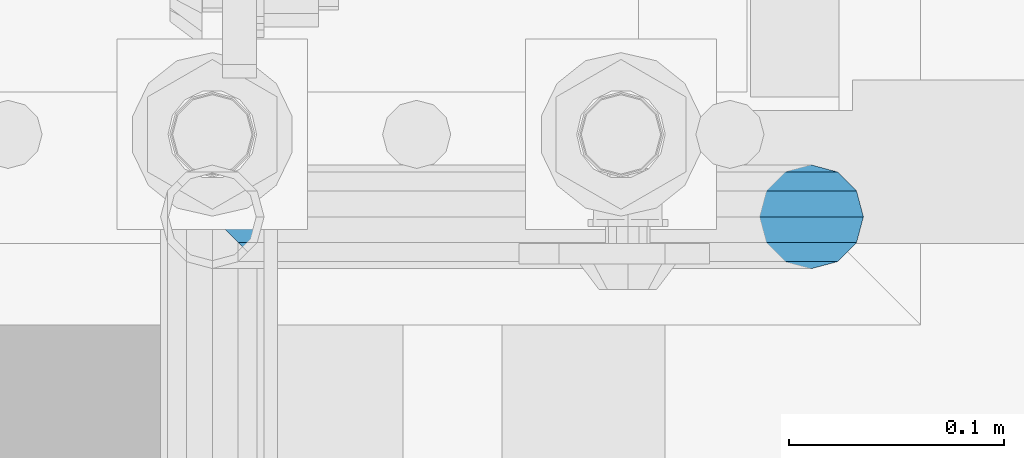
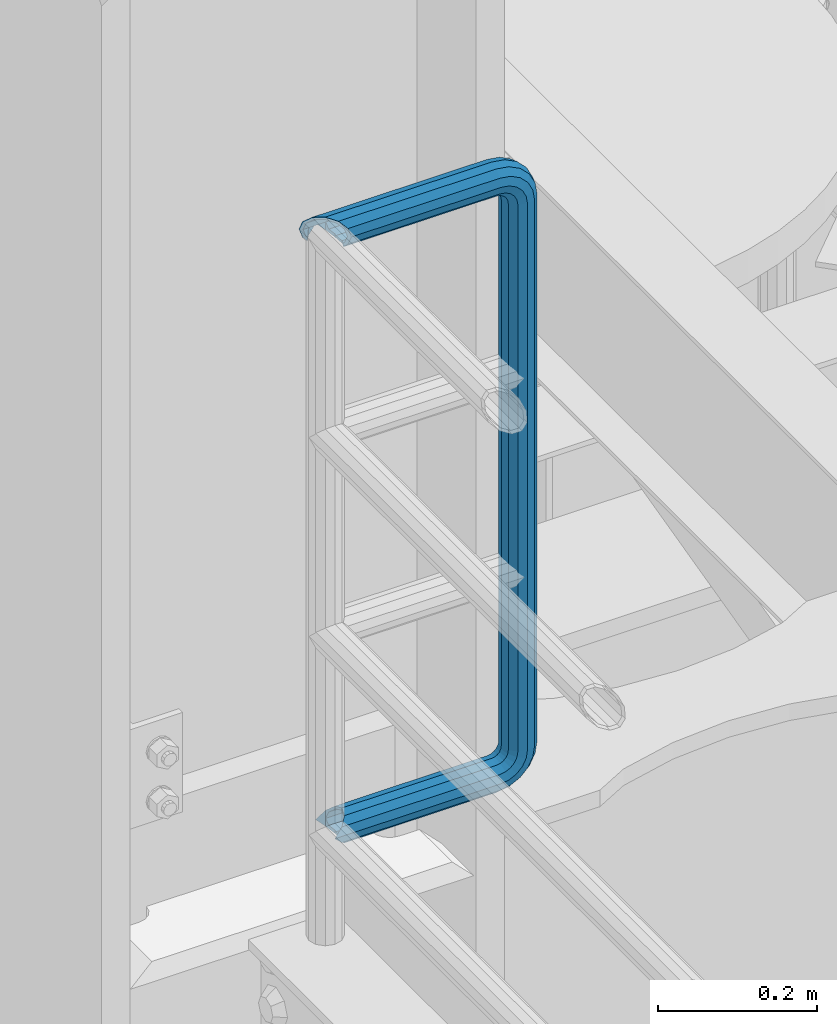
# One storey, part 960 of 1876: 1 beam, 1 element without a shape of its own.
"""IFC2X3 building model written with IfcOpenShell, lengths in millimetres."""

from ifc_helpers import new_model, si_unit, frame, origin_with_axes, place, context, subcontext, project, spatial, faceted_brep, material, type_object, element, aggregate, save


model = new_model("IFC2X3")

# Units and contexts
model_context = context("Model", 3, precision=1e-05, world=origin_with_axes())
body_context = subcontext(model_context, "Body", "Model", "MODEL_VIEW")
ifc_project = project(units=[si_unit("LENGTHUNIT", "METRE", prefix="MILLI"), si_unit("AREAUNIT", "SQUARE_METRE"), si_unit("VOLUMEUNIT", "CUBIC_METRE"), si_unit("MASSUNIT", "GRAM", prefix="KILO"), si_unit("TIMEUNIT", "SECOND"), si_unit("PLANEANGLEUNIT", "RADIAN"), si_unit("SOLIDANGLEUNIT", "STERADIAN"), si_unit("THERMODYNAMICTEMPERATUREUNIT", "DEGREE_CELSIUS"), si_unit("LUMINOUSINTENSITYUNIT", "LUMEN")], contexts=[model_context])

# Site, building, storey
site_placement = place(None, origin_with_axes())
site = spatial("IfcSite", under=ifc_project, at=site_placement, CompositionType="ELEMENT")
building_placement = place(site_placement, origin_with_axes())
building = spatial("IfcBuilding", under=site, at=building_placement, Name="Undefined", CompositionType="ELEMENT")
storey_placement = place(building_placement, origin_with_axes())
storey = spatial("IfcBuildingStorey", under=building, at=storey_placement, Name="Undefined", CompositionType="ELEMENT", Elevation=0.0)

# Assembly, beam
assembly_placement = place(storey_placement, origin_with_axes())
assembly = element("IfcElementAssembly", 1, at=assembly_placement, inside=storey, Name="RAIL", AssemblyPlace="NOTDEFINED", PredefinedType="RIGID_FRAME")
ifc_material = material()
beam_type = type_object("IfcBeamType", Name="PIPE1-1/2SCH40", PredefinedType="NOTDEFINED")
beam_placement = place(assembly_placement, frame((5.00222085975111e-12, -4788.2175, 19059.525), z_axis=(0.0, 0.0, 1.0), x_axis=(1.0, 0.0, 0.0)))
beam = element("IfcBeam", 2, at=beam_placement, type_object=beam_type, material=ifc_material, Name="RAIL", ObjectType="PIPE1-1/2SCH40", context=body_context, shape_type="Brep", body=[
    faceted_brep([(-12.0649999999986, 20.8971929933177, -12.0649999999987), (-12.0649999999986, 20.8971929933186, 0.0), (-12.5151929933171, 20.4470000000001, 0.0), (-15.2545715621367, 17.7076214311801, -10.2235000000001), (-16.4810964966549, 16.4810964966618, -11.4500249345183), (-16.481093238746, 16.4810932387318, -16.4810997545865), (0.0, 24.1299999999992, 0.0), (12.0650000000014, 20.8971929933186, 0.0), (12.5151929933249, 20.4470000000001, 0.0), (12.0650000000064, 20.8971929933177, -12.0649999999987), (15.2545715621445, 17.7076214311801, -10.2235000000001), (20.8971929933249, 12.0650000000005, -20.8971929933177), (20.8971929933249, 12.0650000000005, -15.8661214311796), (20.8971929933249, -12.0650000000005, -15.8661214311796), (20.8971929933249, -12.0650000000005, -20.8971929933177), (16.4810997545745, -16.4810997545883, -16.48109323873), (16.4810964966636, -16.4810964966564, -11.4500249345256), (24.1300000000063, 0.0, -20.4470000000001), (24.1300000000063, 0.0, -24.130000000001), (21.3906214311868, -10.2235000000001, -17.7076214311819), (21.3906214311868, 10.2235000000001, -17.7076214311819), (1.20714750983051e-12, 24.1299999999974, -914.399963378906), (12.0650000000014, 20.8971929933159, -926.464963378905), (12.0650000000014, 20.8971929933177, -902.334963378908), (12.0650000000014, -20.8971929933195, -902.334963378908), (12.0650000000014, -20.8971929933195, -926.464963378905), (1.52133659548828e-12, -24.130000000001, -914.399963378906), (20.8971929933199, -12.0650000000023, -893.502770385589), (20.8971929933199, -12.0650000000005, -898.533841947723), (15.2545715621378, -17.7076214311819, -904.176463378906), (12.5151929933181, -20.4470000000019, -914.399963378906), (15.2545715621376, -17.7076214311819, -924.623463378906), (20.8971929933199, -12.0650000000005, -930.26608481009), (20.8971929933199, -12.0650000000023, -935.297156372224), (24.1300000000014, -1.81898940354586e-12, -934.846963378906), (24.1300000000014, -1.81898940354586e-12, -938.529963378907), (21.3906214311813, -10.2235000000019, -932.107584810088), (21.3906214311823, 10.2234999999982, -932.107584810088), (20.8971929933199, 12.0650000000005, -930.266084810086), (20.8971929933199, 12.0649999999987, -935.297156372224), (15.2545715621413, 17.7076214311783, -924.623463378906), (12.5151929933216, 20.4469999999983, -914.399963378906), (15.2545715621411, 17.7076214311783, -904.176463378906), (20.8971929933199, 12.0650000000005, -898.533841947727), (20.8971929933199, 12.0649999999987, -893.502770385589), (21.3906214311822, 10.2234999999982, -896.692341947724), (24.1300000000014, 0.0, -893.952963378906), (24.1300000000014, 0.0, -890.269963378905), (21.3906214311814, -10.2235000000019, -896.692341947724), (241.299995422363, -20.8971929933177, -12.0649999999987), (241.299995422363, -12.0650000000005, -20.8971929933177), (246.615954666858, -12.0650000000005, -21.7391582230448), (249.345252399393, -20.8971929933177, -13.3392435235728), (241.299995422363, -24.1299999999992, 0.0), (253.073542436527, -24.1299999999992, -1.86474665447167), (241.299995422363, -20.8971929933177, 12.0649999999987), (256.801832473661, -20.8971929933177, 9.60975021462946), (241.299995422363, -12.0650000000005, 20.8971929933177), (259.531130206197, -12.0650000000005, 18.0096649141014), (241.299995422363, 0.0, 24.130000000001), (260.530122510796, 0.0, 21.084247083727), (241.299995422363, 12.0650000000005, 20.8971929933177), (259.531130206197, 12.0650000000005, 18.0096649141014), (241.299995422363, 20.8971929933177, 12.0649999999987), (256.801832473661, 20.8971929933177, 9.60975021462946), (241.299995422363, 24.1299999999992, 0.0), (253.073542436527, 24.1299999999992, -1.86474665447167), (241.299995422363, 20.8971929933177, -12.0649999999987), (249.345252399393, 20.8971929933177, -13.3392435235728), (241.299995422363, 12.0650000000005, -20.8971929933177), (246.615954666858, 12.0650000000005, -21.7391582230448), (241.299995422363, 0.0, -24.130000000001), (245.616962362259, 0.0, -24.8137403926739), (291.464993896486, 20.8971929933177, -38.0999984741211), (300.297186889804, 12.0650000000005, -38.0999984741211), (300.297186889803, 12.0650000000005, -876.299964904785), (291.464993896484, 20.8971929933177, -876.299964904785), (303.529993896486, 0.0, -38.0999984741211), (303.529993896484, 0.0, -876.299964904785), (300.297186889804, -12.0650000000005, -38.0999984741211), (300.297186889803, -12.0650000000005, -876.299964904785), (291.464993896486, -20.8971929933177, -38.0999984741211), (291.464993896484, -20.8971929933177, -876.299964904785), (279.399993896484, -24.1299999999992, -38.0999984741211), (279.399993896484, -24.1299999999992, -876.299964904785), (267.334993896485, -20.8971929933177, -38.0999984741211), (267.334993896484, -20.8971929933177, -876.299964904785), (258.502800903167, -12.0650000000005, -38.0999984741211), (258.502800903166, -12.0650000000005, -876.299964904785), (255.269993896485, 0.0, -38.0999984741211), (255.269993896484, 0.0, -876.299964904785), (258.502800903167, 12.0650000000005, -38.0999984741211), (258.502800903166, 12.0650000000005, -876.299964904785), (267.334993896485, 20.8971929933177, -38.0999984741211), (267.334993896484, 20.8971929933177, -876.299964904785), (279.399993896485, 24.1299999999992, -38.0999984741211), (279.399993896484, 24.1299999999992, -876.299964904785), (277.535247242011, 24.1299999999992, -888.073511918952), (266.06075037291, 20.8971929933177, -884.345221881817), (257.660835673438, 12.0650000000005, -881.615924149282), (254.586253503809, 0.0, -880.616931844681), (257.660835673438, -12.0650000000005, -881.615924149282), (266.06075037291, -20.8971929933177, -884.345221881817), (277.535247242011, -24.130000000001, -888.073511918952), (289.009744111112, -20.8971929933195, -891.801801956084), (297.409658810584, -12.0650000000005, -894.531099688622), (300.484240980214, 0.0, -895.53009199322), (297.409658810584, 12.0650000000005, -894.531099688622), (289.009744111112, 20.8971929933177, -891.801801956084), (241.299995422364, -20.8971929933195, -926.464963378909), (241.299995422363, -24.130000000001, -914.399963378906), (241.299995422363, -20.8971929933195, -902.334963378908), (241.299995422363, -12.0650000000005, -893.502770385589), (241.299995422363, 0.0, -890.269963378909), (241.299995422364, -1.81898940354586e-12, -938.529963378911), (241.299995422364, -12.0650000000005, -935.297156372228), (241.299995422364, 12.0649999999987, -935.297156372228), (241.299995422364, 20.8971929933177, -926.464963378909), (241.299995422364, 24.1299999999992, -914.39996337891), (241.299995422363, 20.8971929933177, -902.334963378908), (241.299995422363, 12.0649999999987, -893.502770385589), (256.801832473666, -20.8971929933195, -924.009713593536), (259.531130206201, -12.0650000000005, -932.409628293008), (253.07354243653, -24.130000000001, -912.535216724435), (249.345252399395, -20.8971929933195, -901.060719855333), (246.615954666859, -12.0650000000005, -892.660805155861), (245.61696236226, 0.0, -889.586222986232), (246.615954666859, 12.0649999999987, -892.660805155861), (249.345252399395, 20.8971929933177, -901.060719855333), (253.07354243653, 24.1299999999992, -912.535216724435), (256.801832473666, 20.8971929933177, -924.009713593536), (259.531130206202, 12.0649999999987, -932.409628293008), (260.530122510801, 0.0, -935.484210462637), (275.977674493608, -12.0650000000005, -924.029695422334), (277.877870775644, 0.0, -926.645091230272), (270.786241706733, -20.8971929933195, -916.884301193139), (263.694612637823, -24.130000000001, -907.123511156005), (256.602983568912, -20.8971929933195, -897.362721118872), (251.411550782037, -12.0650000000005, -890.21732688968), (249.511354500001, 0.0, -887.601931081743), (251.411550782037, 12.0650000000005, -890.21732688968), (256.602983568912, 20.8971929933177, -897.362721118872), (263.694612637823, 24.1299999999992, -907.123511156005), (270.786241706733, 20.8971929933177, -916.884301193139), (275.977674493594, 12.0649999999987, -924.029695422345), (291.645121747852, 0.0, -912.877840258065), (289.029725939912, 12.0650000000005, -910.977643976028), (289.029725939912, -12.0650000000005, -910.977643976028), (281.884331710718, -20.8971929933195, -905.786211189152), (272.123541673585, -24.130000000001, -898.694582120243), (262.362751636451, -20.8971929933195, -891.602953051333), (255.217357407258, -12.0650000000005, -886.411520264461), (252.601961599318, 0.0, -884.511323982424), (255.217357407258, 12.0650000000005, -886.411520264461), (262.362751636451, 20.8971929933177, -891.602953051333), (272.123541673585, 24.1299999999992, -898.694582120243), (281.884331710718, 20.8971929933177, -905.786211189152), (289.009744111112, 20.8971929933177, -22.5981614228222), (277.535247242011, 24.1299999999992, -26.3264514599541), (297.409658810584, 12.0650000000005, -19.8688636902843), (300.484240980213, 0.0, -18.8698713856866), (297.409658810584, -12.0650000000005, -19.8688636902843), (289.009744111112, -20.8971929933177, -22.5981614228222), (277.535247242011, -24.1299999999992, -26.3264514599541), (266.060750372911, -20.8971929933177, -30.0547414970897), (257.660835673439, -12.0650000000005, -32.7840392296275), (254.58625350381, 0.0, -33.7830315342253), (257.660835673439, 12.0650000000005, -32.7840392296275), (266.060750372911, 20.8971929933177, -30.0547414970897), (272.123541673583, 24.1299999999992, -15.7053812586601), (262.362751636451, 20.8971929933177, -22.7970103275729), (281.884331710716, 20.8971929933177, -8.61375218975081), (289.029725939909, 12.0650000000005, -3.42231940287456), (291.645121747848, 0.0, -1.52212312084157), (289.029725939909, -12.0650000000005, -3.42231940287456), (281.884331710716, -20.8971929933177, -8.61375218975081), (272.123541673583, -24.1299999999992, -15.7053812586601), (262.362751636451, -20.8971929933177, -22.7970103275729), (255.217357407257, -12.0650000000005, -27.9884431144455), (252.601961599318, 0.0, -29.8886393964822), (255.217357407257, 12.0650000000005, -27.9884431144455), (256.602983568912, 20.8971929933177, -17.037242260034), (251.411550782037, 12.0650000000005, -24.1826364892258), (263.694612637822, 24.1299999999992, -7.27645222290084), (270.786241706732, 20.8971929933177, 2.48433781423228), (275.977674493607, 12.0650000000005, 9.62973204342416), (277.877870775642, 0.0, 12.2451278513654), (275.977674493607, -12.0650000000005, 9.62973204342416), (270.786241706732, -20.8971929933177, 2.48433781423228), (263.694612637822, -24.1299999999992, -7.27645222290084), (256.602983568912, -20.8971929933177, -17.037242260034), (251.411550782037, -12.0650000000005, -24.1826364892258), (249.511354500002, 0.0, -26.7980322971671), (-20.897192993333, 20.8971929933177, -12.0649999999987), (-24.1300000000145, 24.1299999999992, 0.0), (-20.897192993333, 20.8971929933177, 12.0649999999987), (-12.0650000000145, 12.0650000000005, 20.8971929933177), (-1.45519152283669e-11, 0.0, 24.130000000001), (12.0649999999854, -12.0650000000005, 20.8971929933177), (20.8971929933039, -20.8971929933177, 12.0649999999987), (24.1299999999854, -24.1299999999992, 0.0), (20.8971929933039, -20.8971929933177, -12.0649999999987), (241.299995422363, -17.7076214311801, 10.2235000000001), (241.299995422363, -20.4470000000001, 0.0), (20.4469999999854, -20.4470000000001, 0.0), (17.7076214311658, -17.7076214311801, 10.2235000000001), (241.299995422363, -17.7076214311801, -10.2235000000001), (17.7076214311658, -17.7076214311801, -10.2235000000001), (241.299995422363, -10.2235000000001, -17.7076214311819), (241.299995422363, 0.0, -20.4470000000001), (241.299995422363, 0.0, 20.4470000000001), (241.299995422363, -10.2235000000001, 17.7076214311819), (10.2234999999854, -10.2235000000001, 17.7076214311819), (-1.45519152283669e-11, 0.0, 20.4470000000001), (241.299995422363, 10.2235000000001, 17.7076214311819), (-10.2235000000145, 10.2235000000001, 17.7076214311819), (241.299995422363, 17.7076214311801, 10.2235000000001), (-17.7076214311949, 17.7076214311801, 10.2235000000001), (-17.7076214311949, 17.7076214311801, -10.2235000000001), (-20.4470000000145, 20.4470000000001, 0.0), (241.299995422363, 20.4470000000001, 0.0), (241.299995422363, 17.7076214311801, -10.2235000000001), (241.299995422363, 10.2235000000001, -17.7076214311819), (258.545498388721, -10.2235000000001, 14.9762020957387), (256.23277767852, -17.7076214311801, 7.85837963987069), (253.073542436527, -20.4470000000001, -1.86474665447167), (249.914307194535, -17.7076214311801, -11.5878729488177), (247.601586484334, -10.2235000000001, -18.7056954046857), (246.755071952542, 0.0, -21.31099924316), (247.601586484334, 10.2235000000001, -18.7056954046857), (249.914307194535, 17.7076214311801, -11.5878729488177), (253.073542436527, 20.4470000000001, -1.86474665447167), (256.23277767852, 17.7076214311801, 7.85837963987069), (258.545498388721, 10.2235000000001, 14.9762020957387), (259.392012920513, 0.0, 17.5815059342131), (275.713057691449, 0.0, 9.26551826108334), (274.10289136825, -10.2235000000001, 7.04931444488102), (274.10289136825, 10.2235000000001, 7.04931444488102), (269.703835164635, 17.7076214311801, 0.994533019089431), (263.694612637822, 20.4470000000001, -7.27645222290084), (257.685390111009, 17.7076214311801, -15.5474374648911), (253.286333907394, 10.2235000000001, -21.6022188906827), (251.676167584195, 0.0, -23.818422706885), (253.286333907394, -10.2235000000001, -21.6022188906827), (257.685390111009, -17.7076214311801, -15.5474374648911), (263.694612637822, -20.4470000000001, -7.27645222290084), (269.703835164635, -17.7076214311801, 0.994533019089431), (286.449308341364, -10.2235000000001, -5.29710252823133), (280.394526915574, -17.7076214311801, -9.69615873184739), (288.665512157566, 0.0, -3.68693620503473), (286.449308341364, 10.2235000000001, -5.29710252823133), (280.394526915574, 17.7076214311801, -9.69615873184739), (272.123541673583, 20.4470000000001, -15.7053812586601), (263.852556431592, 17.7076214311801, -21.7146037854764), (257.797775005802, 10.2235000000001, -26.1136599890888), (255.581571189601, 0.0, -27.723826312289), (257.797775005802, -10.2235000000001, -26.1136599890888), (263.852556431592, -17.7076214311801, -21.7146037854764), (272.123541673583, -20.4470000000001, -15.7053812586601), (287.258373536355, -17.7076214311801, -23.1672162179639), (277.535247242011, -20.4470000000001, -26.3264514599541), (294.376195992223, -10.2235000000001, -20.8544955077632), (296.981499830698, 0.0, -20.00798097597), (294.376195992223, 10.2235000000001, -20.8544955077632), (287.258373536355, 17.7076214311801, -23.1672162179639), (277.535247242011, 20.4470000000001, -26.3264514599541), (267.812120947668, 17.7076214311801, -29.485686701948), (260.6942984918, 10.2235000000001, -31.7984074121487), (258.088994653325, 0.0, -32.6449219439419), (260.6942984918, -10.2235000000001, -31.7984074121487), (267.812120947668, -17.7076214311801, -29.485686701948), (279.399993896484, -20.4470000000001, -38.0999984741211), (269.176493896485, -17.7076214311801, -38.0999984741211), (289.623493896486, -17.7076214311801, -38.0999984741211), (297.107615327666, -10.2235000000001, -38.0999984741211), (299.846993896486, 0.0, -38.0999984741211), (297.107615327666, 10.2235000000001, -38.0999984741211), (289.623493896486, 17.7076214311801, -38.0999984741211), (279.399993896485, 20.4470000000001, -38.0999984741211), (269.176493896485, 17.7076214311801, -38.0999984741211), (261.692372465305, 10.2235000000001, -38.0999984741211), (258.952993896485, 0.0, -38.0999984741211), (261.692372465305, -10.2235000000001, -38.0999984741211), (269.176493896484, -17.7076214311801, -876.299964904785), (261.692372465304, -10.2235000000001, -876.299964904785), (258.952993896484, 0.0, -876.299964904785), (261.692372465304, 10.2235000000001, -876.299964904785), (269.176493896484, 17.7076214311801, -876.299964904785), (279.399993896484, 20.4470000000001, -876.299964904785), (289.623493896484, 17.7076214311801, -876.299964904785), (297.107615327665, 10.2235000000001, -876.299964904785), (299.846993896484, 0.0, -876.299964904785), (297.107615327665, -10.2235000000001, -876.299964904785), (289.623493896484, -17.7076214311801, -876.299964904785), (279.399993896484, -20.4470000000001, -876.299964904785), (277.535247242011, -20.4470000000001, -888.073511918952), (267.812120947667, -17.7076214311801, -884.914276676958), (260.694298491799, -10.2235000000001, -882.601555966758), (258.088994653324, 0.0, -881.755041434964), (260.694298491799, 10.2235000000001, -882.601555966758), (267.812120947668, 17.7076214311801, -884.914276676958), (277.535247242011, 20.4470000000001, -888.073511918952), (287.258373536355, 17.7076214311801, -891.232747160942), (294.376195992223, 10.2235000000001, -893.545467871143), (296.981499830699, 0.0, -894.391982402936), (294.376195992223, -10.2235000000001, -893.545467871143), (287.258373536355, -17.7076214311801, -891.232747160942), (280.394526915577, -17.7076214311801, -904.703804647055), (272.123541673585, -20.4470000000001, -898.694582120243), (286.449308341367, -10.2235000000001, -909.102860850671), (288.665512157569, 0.0, -910.713027173868), (286.449308341367, 10.2235000000001, -909.102860850671), (280.394526915577, 17.7076214311801, -904.703804647055), (272.123541673585, 20.4470000000001, -898.694582120243), (263.852556431593, 17.7076214311801, -892.68535959343), (257.797775005802, 10.2235000000001, -888.286303389817), (255.581571189601, 0.0, -886.676137066617), (257.797775005802, -10.2235000000001, -888.286303389817), (263.852556431593, -17.7076214311801, -892.68535959343), (263.694612637823, -20.4470000000001, -907.123511156005), (257.685390111009, -17.7076214311801, -898.852525914015), (269.703835164636, -17.7076214311801, -915.394496397999), (274.102891368238, -10.2235000000001, -921.449277823798), (275.71305769145, 0.0, -923.66548163999), (274.102891368251, 10.2235000000001, -921.449277823787), (269.703835164636, 17.7076214311801, -915.394496397999), (263.694612637823, 20.4470000000001, -907.123511156005), (257.685390111009, 17.7076214311801, -898.852525914015), (253.286333907394, 10.2235000000001, -892.797744488227), (251.676167584195, 0.0, -890.581540672025), (253.286333907394, -10.2235000000001, -892.797744488227), (249.914307194537, -17.7076214311801, -902.812090430092), (247.601586484335, -10.2235000000001, -895.694267974224), (253.07354243653, -20.4470000000001, -912.535216724435), (256.232777678524, -17.7076214311819, -922.258343018777), (258.545498388725, -10.2235000000001, -929.376165474645), (259.392012920517, 0.0, -931.981469313119), (258.545498388725, 10.2235000000001, -929.376165474645), (256.232777678524, 17.7076214311801, -922.258343018777), (253.07354243653, 20.4470000000001, -912.535216724435), (249.914307194537, 17.7076214311801, -902.812090430092), (247.601586484335, 10.2235000000001, -895.694267974224), (246.755071952543, 0.0, -893.088964135746), (241.299995422363, -10.2235000000001, -896.692341947728), (241.299995422363, 0.0, -893.95296337891), (241.299995422363, -17.7076214311819, -904.17646337891), (241.299995422363, -20.4470000000001, -914.399963378906), (241.299995422364, -17.7076214311819, -924.62346337891), (241.299995422364, -10.2235000000001, -932.107584810088), (241.299995422364, -1.81898940354586e-12, -934.84696337891), (241.299995422364, 10.2234999999982, -932.107584810088), (241.299995422364, 17.7076214311801, -924.62346337891), (241.299995422364, 20.4470000000001, -914.39996337891), (241.299995422363, 17.7076214311801, -904.17646337891), (241.299995422363, 10.2235000000001, -896.692341947728)], [[[0, 1, 2, 3, 4, 5]], [[6, 1, 0]], [[2, 1, 6, 7, 8]], [[9, 7, 6]], [[10, 8, 7, 9, 11, 12]], [[13, 14, 15, 16]], [[17, 18, 14, 13, 19]], [[20, 12, 11, 18, 17]], [[21, 22, 23]], [[24, 25, 26]], [[27, 28, 29, 30, 31, 32, 33, 25, 24]], [[34, 35, 33, 32, 36]], [[37, 38, 39, 35, 34]], [[23, 22, 39, 38, 40, 41, 42, 43, 44]], [[44, 43, 45, 46, 47]], [[47, 46, 48, 28, 27]], [[49, 50, 51, 52]], [[53, 49, 52, 54]], [[55, 53, 54, 56]], [[57, 55, 56, 58]], [[59, 57, 58, 60]], [[61, 59, 60, 62]], [[63, 61, 62, 64]], [[65, 63, 64, 66]], [[67, 65, 66, 68]], [[69, 67, 68, 70]], [[71, 69, 70, 72]], [[73, 74, 75, 76]], [[74, 77, 78, 75]], [[77, 79, 80, 78]], [[79, 81, 82, 80]], [[81, 83, 84, 82]], [[83, 85, 86, 84]], [[85, 87, 88, 86]], [[87, 89, 90, 88]], [[89, 91, 92, 90]], [[91, 93, 94, 92]], [[93, 95, 96, 94]], [[94, 96, 97, 98]], [[92, 94, 98, 99]], [[90, 92, 99, 100]], [[88, 90, 100, 101]], [[86, 88, 101, 102]], [[84, 86, 102, 103]], [[82, 84, 103, 104]], [[80, 82, 104, 105]], [[78, 80, 105, 106]], [[75, 78, 106, 107]], [[76, 75, 107, 108]], [[109, 110, 26, 25]], [[110, 111, 24, 26]], [[111, 112, 27, 24]], [[112, 113, 47, 27]], [[114, 115, 33, 35]], [[116, 114, 35, 39]], [[117, 116, 39, 22]], [[118, 117, 22, 21]], [[119, 118, 21, 23]], [[120, 119, 23, 44]], [[113, 120, 44, 47]], [[115, 109, 25, 33]], [[121, 109, 115, 122]], [[123, 110, 109, 121]], [[124, 111, 110, 123]], [[125, 112, 111, 124]], [[126, 113, 112, 125]], [[127, 120, 113, 126]], [[128, 119, 120, 127]], [[129, 118, 119, 128]], [[130, 117, 118, 129]], [[131, 116, 117, 130]], [[132, 114, 116, 131]], [[122, 115, 114, 132]], [[133, 122, 132, 134]], [[135, 121, 122, 133]], [[136, 123, 121, 135]], [[137, 124, 123, 136]], [[138, 125, 124, 137]], [[139, 126, 125, 138]], [[140, 127, 126, 139]], [[141, 128, 127, 140]], [[142, 129, 128, 141]], [[143, 130, 129, 142]], [[144, 131, 130, 143]], [[134, 132, 131, 144]], [[145, 134, 144, 146]], [[147, 133, 134, 145]], [[148, 135, 133, 147]], [[149, 136, 135, 148]], [[150, 137, 136, 149]], [[151, 138, 137, 150]], [[152, 139, 138, 151]], [[153, 140, 139, 152]], [[154, 141, 140, 153]], [[155, 142, 141, 154]], [[156, 143, 142, 155]], [[146, 144, 143, 156]], [[107, 146, 156, 108]], [[106, 145, 146, 107]], [[105, 147, 145, 106]], [[104, 148, 147, 105]], [[103, 149, 148, 104]], [[102, 150, 149, 103]], [[101, 151, 150, 102]], [[100, 152, 151, 101]], [[99, 153, 152, 100]], [[98, 154, 153, 99]], [[97, 155, 154, 98]], [[108, 156, 155, 97]], [[96, 76, 108, 97]], [[95, 73, 76, 96]], [[157, 73, 95, 158]], [[159, 74, 73, 157]], [[160, 77, 74, 159]], [[161, 79, 77, 160]], [[162, 81, 79, 161]], [[163, 83, 81, 162]], [[164, 85, 83, 163]], [[165, 87, 85, 164]], [[166, 89, 87, 165]], [[167, 91, 89, 166]], [[168, 93, 91, 167]], [[158, 95, 93, 168]], [[169, 158, 168, 170]], [[171, 157, 158, 169]], [[172, 159, 157, 171]], [[173, 160, 159, 172]], [[174, 161, 160, 173]], [[175, 162, 161, 174]], [[176, 163, 162, 175]], [[177, 164, 163, 176]], [[178, 165, 164, 177]], [[179, 166, 165, 178]], [[180, 167, 166, 179]], [[170, 168, 167, 180]], [[181, 170, 180, 182]], [[183, 169, 170, 181]], [[184, 171, 169, 183]], [[185, 172, 171, 184]], [[186, 173, 172, 185]], [[187, 174, 173, 186]], [[188, 175, 174, 187]], [[189, 176, 175, 188]], [[190, 177, 176, 189]], [[191, 178, 177, 190]], [[192, 179, 178, 191]], [[182, 180, 179, 192]], [[70, 182, 192, 72]], [[68, 181, 182, 70]], [[66, 183, 181, 68]], [[64, 184, 183, 66]], [[62, 185, 184, 64]], [[60, 186, 185, 62]], [[58, 187, 186, 60]], [[56, 188, 187, 58]], [[54, 189, 188, 56]], [[52, 190, 189, 54]], [[51, 191, 190, 52]], [[72, 192, 191, 51]], [[50, 71, 72, 51]], [[71, 50, 14, 18]], [[69, 71, 18, 11]], [[67, 69, 11, 9]], [[65, 67, 9, 6]], [[193, 0, 5]], [[193, 194, 6, 0]], [[63, 65, 6, 194, 195]], [[61, 63, 195, 196]], [[59, 61, 196, 197]], [[57, 59, 197, 198]], [[55, 57, 198, 199]], [[53, 55, 199, 200]], [[49, 53, 200, 201]], [[50, 49, 201, 15, 14]], [[202, 203, 204, 205]], [[203, 206, 207, 204]], [[16, 207, 206, 208, 19, 13]], [[208, 209, 17, 19]], [[210, 211, 212, 213]], [[214, 210, 213, 215]], [[216, 214, 215, 217]], [[218, 4, 3]], [[219, 218, 3, 2]], [[220, 216, 217, 219, 2, 8]], [[221, 220, 8, 10]], [[222, 221, 10, 12, 20]], [[209, 222, 20, 17]], [[201, 200, 199, 198, 197, 196, 195, 194, 193, 5, 4, 218, 219, 217, 215, 213, 212, 205, 204, 207, 16, 15]], [[211, 202, 205, 212]], [[202, 211, 223, 224]], [[203, 202, 224, 225]], [[206, 203, 225, 226]], [[208, 206, 226, 227]], [[209, 208, 227, 228]], [[222, 209, 228, 229]], [[221, 222, 229, 230]], [[220, 221, 230, 231]], [[216, 220, 231, 232]], [[214, 216, 232, 233]], [[210, 214, 233, 234]], [[211, 210, 234, 223]], [[234, 235, 236, 223]], [[233, 237, 235, 234]], [[232, 238, 237, 233]], [[231, 239, 238, 232]], [[230, 240, 239, 231]], [[229, 241, 240, 230]], [[228, 242, 241, 229]], [[227, 243, 242, 228]], [[226, 244, 243, 227]], [[225, 245, 244, 226]], [[224, 246, 245, 225]], [[223, 236, 246, 224]], [[236, 247, 248, 246]], [[235, 249, 247, 236]], [[237, 250, 249, 235]], [[238, 251, 250, 237]], [[239, 252, 251, 238]], [[240, 253, 252, 239]], [[241, 254, 253, 240]], [[242, 255, 254, 241]], [[243, 256, 255, 242]], [[244, 257, 256, 243]], [[245, 258, 257, 244]], [[246, 248, 258, 245]], [[248, 259, 260, 258]], [[247, 261, 259, 248]], [[249, 262, 261, 247]], [[250, 263, 262, 249]], [[251, 264, 263, 250]], [[252, 265, 264, 251]], [[253, 266, 265, 252]], [[254, 267, 266, 253]], [[255, 268, 267, 254]], [[256, 269, 268, 255]], [[257, 270, 269, 256]], [[258, 260, 270, 257]], [[260, 271, 272, 270]], [[259, 273, 271, 260]], [[261, 274, 273, 259]], [[262, 275, 274, 261]], [[263, 276, 275, 262]], [[264, 277, 276, 263]], [[265, 278, 277, 264]], [[266, 279, 278, 265]], [[267, 280, 279, 266]], [[268, 281, 280, 267]], [[269, 282, 281, 268]], [[270, 272, 282, 269]], [[282, 272, 283, 284]], [[281, 282, 284, 285]], [[280, 281, 285, 286]], [[279, 280, 286, 287]], [[278, 279, 287, 288]], [[277, 278, 288, 289]], [[276, 277, 289, 290]], [[275, 276, 290, 291]], [[274, 275, 291, 292]], [[273, 274, 292, 293]], [[271, 273, 293, 294]], [[272, 271, 294, 283]], [[283, 294, 295, 296]], [[284, 283, 296, 297]], [[285, 284, 297, 298]], [[286, 285, 298, 299]], [[287, 286, 299, 300]], [[288, 287, 300, 301]], [[289, 288, 301, 302]], [[290, 289, 302, 303]], [[291, 290, 303, 304]], [[292, 291, 304, 305]], [[293, 292, 305, 306]], [[294, 293, 306, 295]], [[306, 307, 308, 295]], [[305, 309, 307, 306]], [[304, 310, 309, 305]], [[303, 311, 310, 304]], [[302, 312, 311, 303]], [[301, 313, 312, 302]], [[300, 314, 313, 301]], [[299, 315, 314, 300]], [[298, 316, 315, 299]], [[297, 317, 316, 298]], [[296, 318, 317, 297]], [[295, 308, 318, 296]], [[308, 319, 320, 318]], [[307, 321, 319, 308]], [[309, 322, 321, 307]], [[310, 323, 322, 309]], [[311, 324, 323, 310]], [[312, 325, 324, 311]], [[313, 326, 325, 312]], [[314, 327, 326, 313]], [[315, 328, 327, 314]], [[316, 329, 328, 315]], [[317, 330, 329, 316]], [[318, 320, 330, 317]], [[320, 331, 332, 330]], [[319, 333, 331, 320]], [[321, 334, 333, 319]], [[322, 335, 334, 321]], [[323, 336, 335, 322]], [[324, 337, 336, 323]], [[325, 338, 337, 324]], [[326, 339, 338, 325]], [[327, 340, 339, 326]], [[328, 341, 340, 327]], [[329, 342, 341, 328]], [[330, 332, 342, 329]], [[332, 343, 344, 342]], [[331, 345, 343, 332]], [[333, 346, 345, 331]], [[334, 347, 346, 333]], [[335, 348, 347, 334]], [[336, 349, 348, 335]], [[337, 350, 349, 336]], [[338, 351, 350, 337]], [[339, 352, 351, 338]], [[340, 353, 352, 339]], [[341, 354, 353, 340]], [[342, 344, 354, 341]], [[354, 344, 46, 45]], [[42, 353, 354, 45, 43]], [[352, 353, 42, 41]], [[351, 352, 41, 40]], [[350, 351, 40, 38, 37]], [[349, 350, 37, 34]], [[348, 349, 34, 36]], [[31, 347, 348, 36, 32]], [[346, 347, 31, 30]], [[345, 346, 30, 29]], [[343, 345, 29, 28, 48]], [[344, 343, 48, 46]]]),
])
aggregate(assembly, [beam])

save(model, "model.ifc")
